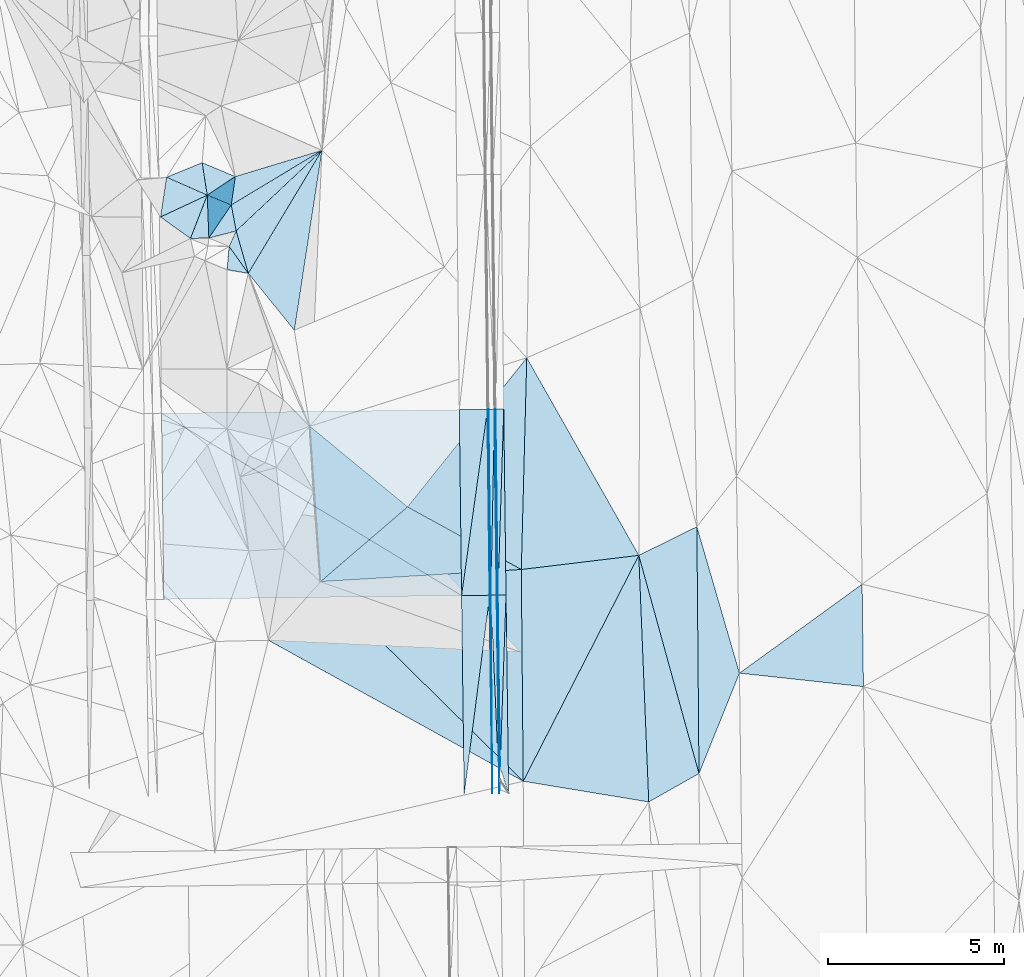
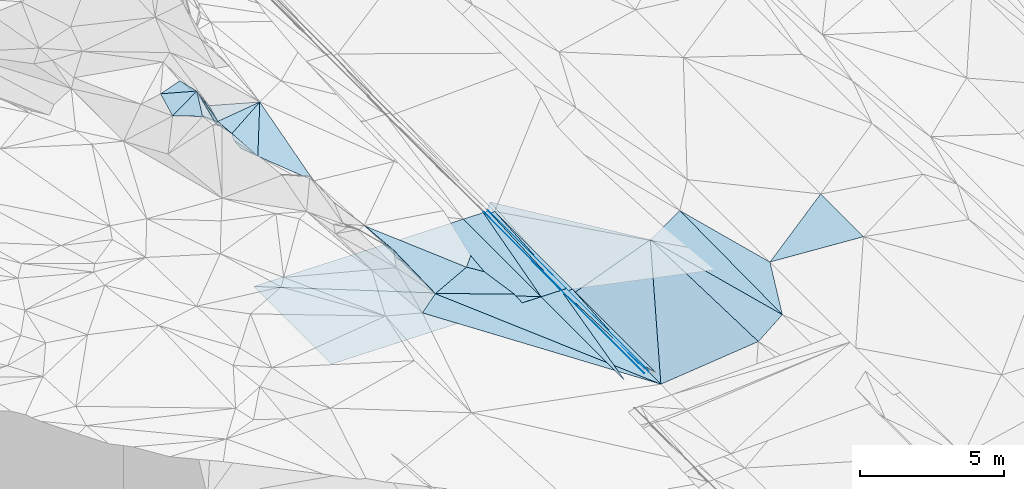
# One storey, part 15 of 275: 46 plates.
"""IFC2X3 building model written with IfcOpenShell, lengths in millimetres."""

from ifc_helpers import new_model, si_unit, frame, origin_with_axes, place, context, subcontext, project, spatial, polyline, outline, extrude, material, type_object, element, save


model = new_model("IFC2X3")

# Units and contexts
model_context = context("Model", 3, precision=1e-05, world=origin_with_axes())
body_context = subcontext(model_context, "Body", "Model", "MODEL_VIEW")
ifc_project = project(units=[si_unit("LENGTHUNIT", "METRE", prefix="MILLI"), si_unit("AREAUNIT", "SQUARE_METRE"), si_unit("VOLUMEUNIT", "CUBIC_METRE"), si_unit("MASSUNIT", "GRAM", prefix="KILO"), si_unit("TIMEUNIT", "SECOND"), si_unit("PLANEANGLEUNIT", "RADIAN"), si_unit("SOLIDANGLEUNIT", "STERADIAN"), si_unit("THERMODYNAMICTEMPERATUREUNIT", "DEGREE_CELSIUS"), si_unit("LUMINOUSINTENSITYUNIT", "LUMEN")], contexts=[model_context])

# Site, building, storey
site_placement = place(None, origin_with_axes())
site = spatial("IfcSite", under=ifc_project, at=site_placement, CompositionType="ELEMENT")
building_placement = place(site_placement, origin_with_axes())
building = spatial("IfcBuilding", under=site, at=building_placement, Name="Undefined", CompositionType="ELEMENT")
storey_placement = place(building_placement, origin_with_axes())
storey = spatial("IfcBuildingStorey", under=building, at=storey_placement, Name="Undefined", CompositionType="ELEMENT", Elevation=0.0)

# Plates
ifc_material = material()
plate_type_1 = type_object("IfcPlateType", PredefinedType="NOTDEFINED")
plate_1_placement = place(storey_placement, frame((-93645.5654127014, 6924.88176005127, 41050.6337426774), z_axis=(-0.970123201370092, -0.00671580462623567, -0.242519838635247), x_axis=(-0.242493457937885, -0.00450982198549851, 0.970142558783495)))
element("IfcPlate", 1, at=plate_1_placement, inside=storey, type_object=plate_type_1, material=ifc_material, Name="00_PR", context=body_context, shape_type="SweptSolid", body=[
    extrude(outline(polyline([(0.0, 0.0), (123.693176269531, -2.18278728425503e-11), (223.490829467773, 5268.44970703125), (0.0, 0.0)])), frame((-8.85201319254618e-08, 2.18876761149539e-07, -0.5000001331573), z_axis=(0.0, 0.0, 1.0), x_axis=(1.0, 0.0, 0.0)), (0.0, 0.0, 1.0), 1.0),
])
plate_2_placement = place(storey_placement, frame((-93582.0000382841, 2050.47414850637, 40946.8437420977), z_axis=(-0.970117044837282, -0.00748696234688832, -0.242521885014518), x_axis=(-0.0191726281131406, 0.998763884216836, 0.0458597199657052)))
element("IfcPlate", 2, at=plate_2_placement, inside=storey, type_object=plate_type_1, material=ifc_material, Name="00_PR", context=body_context, shape_type="SweptSolid", body=[
    extrude(outline(polyline([(0.0, 0.0), (4879.88134765625, -1.38970790430903e-09), (4874.3603515625, 123.569885253906), (0.0, 0.0)])), frame((-8.85201319254618e-08, 2.18876761149539e-07, -0.5000001331573), z_axis=(0.0, 0.0, 1.0), x_axis=(1.0, 0.0, 0.0)), (0.0, 0.0, 1.0), 1.0),
])
plate_3_placement = place(storey_placement, frame((-93601.8818309884, 1303.71746638813, 41050.9489987877), z_axis=(-0.97074095165136, -0.0076143507417692, -0.240008388290478), x_axis=(-0.0131045751041167, 0.999687507594542, 0.0212874909454562)))
element("IfcPlate", 3, at=plate_3_placement, inside=storey, type_object=plate_type_1, material=ifc_material, Name="00_PR", context=body_context, shape_type="SweptSolid", body=[
    extrude(outline(polyline([(0.0, 0.0), (5622.36279296875, -5.0931703299284e-11), (744.046630859375, 123.583992004395), (0.0, 0.0)])), frame((-8.85201319254618e-08, 2.18876761149539e-07, -0.5000001331573), z_axis=(0.0, 0.0, 1.0), x_axis=(1.0, 0.0, 0.0)), (0.0, 0.0, 1.0), 1.0),
])
plate_4_placement = place(storey_placement, frame((-93645.5654408981, 6924.88175349419, 41050.6338539226), z_axis=(-0.970178666674634, -0.00672655828869441, -0.2422975611578), x_axis=(-0.0178796491174188, 0.998877629724675, 0.0438611329431022)))
element("IfcPlate", 4, at=plate_4_placement, inside=storey, type_object=plate_type_1, material=ifc_material, Name="00_PR", context=body_context, shape_type="SweptSolid", body=[
    extrude(outline(polyline([(0.0, 0.0), (5273.18798828125, -2.29920260608196e-09), (5268.7587890625, 123.611724853516), (0.0, 0.0)])), frame((-8.85201319254618e-08, 2.18876761149539e-07, -0.5000001331573), z_axis=(0.0, 0.0, 1.0), x_axis=(1.0, 0.0, 0.0)), (0.0, 0.0, 1.0), 1.0),
])
plate_type_2 = type_object("IfcPlateType", PredefinedType="NOTDEFINED")
plate_5_placement = place(storey_placement, frame((-93939.3591804414, 12189.8120548934, 41282.1432122279), z_axis=(-0.0202381755240931, 0.0208694723215139, -0.999577351372308), x_axis=(0.999730993002575, 0.0117517851009575, -0.0199959290113252)))
element("IfcPlate", 5, at=plate_5_placement, inside=storey, type_object=plate_type_2, material=ifc_material, Name="00_PR", context=body_context, shape_type="SweptSolid", body=[
    extrude(outline(polyline([(0.0, 0.0), (30.0061073303223, -1.96450855582953e-10), (34.5950012207031, 5269.541015625), (0.0, 0.0)])), frame((-8.85201319254618e-08, 2.18876761149539e-07, -0.5000001331573), z_axis=(0.0, 0.0, 1.0), x_axis=(1.0, 0.0, 0.0)), (0.0, 0.0, 1.0), 1.0),
])
plate_6_placement = place(storey_placement, frame((-93845.0721593397, 6922.18920606923, 41170.2552141594), z_axis=(-0.0202593645784739, 0.0210187891176736, -0.999573793499461), x_axis=(0.00776926009786083, -0.999745493529568, -0.0211798669696531)))
element("IfcPlate", 6, at=plate_6_placement, inside=storey, type_object=plate_type_2, material=ifc_material, Name="00_PR", context=body_context, shape_type="SweptSolid", body=[
    extrude(outline(polyline([(0.0, 0.0), (5622.60400390625, 5.23868948221207e-10), (0.133674800395966, 30.0051765441895), (0.0, 0.0)])), frame((-8.85201319254618e-08, 2.18876761149539e-07, -0.5000001331573), z_axis=(0.0, 0.0, 1.0), x_axis=(1.0, 0.0, 0.0)), (0.0, 0.0, 1.0), 1.0),
])
plate_7_placement = place(storey_placement, frame((-93845.0721599937, 6922.18913180078, 41170.2552143476), z_axis=(-0.0202569271524092, 0.020869125753764, -0.999576978772828), x_axis=(-0.999720037211024, -0.0126488381103916, 0.0199963519984289)))
element("IfcPlate", 7, at=plate_7_placement, inside=storey, type_object=plate_type_2, material=ifc_material, Name="00_PR", context=body_context, shape_type="SweptSolid", body=[
    extrude(outline(polyline([(0.0, 0.0), (30.0054740905762, 1.32786226458848e-10), (29.8686790466309, 5269.56982421875), (0.0, 0.0)])), frame((-8.85201319254618e-08, 2.18876761149539e-07, -0.5000001331573), z_axis=(0.0, 0.0, 1.0), x_axis=(1.0, 0.0, 0.0)), (0.0, 0.0, 1.0), 1.0),
])
plate_type_3 = type_object("IfcPlateType", PredefinedType="NOTDEFINED")
plate_8_placement = place(storey_placement, frame((-93939.3591804414, 12189.8120548934, 41282.1432122279), z_axis=(-0.0202389360534142, 0.0208665514569433, -0.999577396952192), x_axis=(-0.138020329921821, -0.99026803217576, -0.0178777229819364)))
element("IfcPlate", 8, at=plate_8_placement, inside=storey, type_object=plate_type_3, material=ifc_material, Name="00_PR", context=body_context, shape_type="SweptSolid", body=[
    extrude(outline(polyline([(0.0, 0.0), (5329.9853515625, -2.91038304567337e-09), (119.44327545166, 791.195007324219), (0.0, 0.0)])), frame((-8.85201319254618e-08, 2.18876761149539e-07, -0.5000001331573), z_axis=(0.0, 0.0, 1.0), x_axis=(1.0, 0.0, 0.0)), (0.0, 0.0, 1.0), 1.0),
])
plate_9_placement = place(storey_placement, frame((-94675.0055140679, 6911.69801335539, 41186.8552116675), z_axis=(-0.0202569271524092, 0.020869125753764, -0.999576978772828), x_axis=(0.138020329921778, 0.990268032175784, 0.0178777229809464)))
element("IfcPlate", 9, at=plate_9_placement, inside=storey, type_object=plate_type_3, material=ifc_material, Name="00_PR", context=body_context, shape_type="SweptSolid", body=[
    extrude(outline(polyline([(0.0, 0.0), (5329.9853515625, -2.91038304567337e-09), (120.134590148926, 791.090393066406), (0.0, 0.0)])), frame((-8.85201319254618e-08, 2.18876761149539e-07, -0.5000001331573), z_axis=(0.0, 0.0, 1.0), x_axis=(1.0, 0.0, 0.0)), (0.0, 0.0, 1.0), 1.0),
])
plate_10_placement = place(storey_placement, frame((-93875.0692322722, 6921.80967036552, 41170.8552142515), z_axis=(-0.0202587211165812, 0.0210159665238338, -0.999573865889755), x_axis=(-0.127877384951844, -0.991621931419623, -0.0182570409840726)))
element("IfcPlate", 10, at=plate_10_placement, inside=storey, type_object=plate_type_3, material=ifc_material, Name="00_PR", context=body_context, shape_type="SweptSolid", body=[
    extrude(outline(polyline([(0.0, 0.0), (5679.2333984375, 5.54427970200777e-09), (112.028503417969, 792.278930664063), (0.0, 0.0)])), frame((-8.85201319254618e-08, 2.18876761149539e-07, -0.5000001331573), z_axis=(0.0, 0.0, 1.0), x_axis=(1.0, 0.0, 0.0)), (0.0, 0.0, 1.0), 1.0),
])
plate_type_4 = type_object("IfcPlateType", PredefinedType="NOTDEFINED")
plate_11_placement = place(storey_placement, frame((-101064.573224527, 17248.2101642047, 44049.5576733363), z_axis=(-0.448187377193277, 0.128640285215937, -0.884635377963245), x_axis=(0.703618186996102, 0.661171973151793, -0.260332611954175)))
element("IfcPlate", 11, at=plate_11_placement, inside=storey, type_object=plate_type_4, material=ifc_material, Name="00", context=body_context, shape_type="SweptSolid", body=[
    extrude(outline(polyline([(0.0, 0.0), (3457.11596679688, -1.42899807542562e-08), (-461.853179931641, 1210.40307617188), (0.0, 0.0)])), frame((-8.85201319254618e-08, 2.18876761149539e-07, -0.5000001331573), z_axis=(0.0, 0.0, 1.0), x_axis=(1.0, 0.0, 0.0)), (0.0, 0.0, 1.0), 1.0),
])
plate_type_5 = type_object("IfcPlateType", PredefinedType="NOTDEFINED")
plate_12_placement = place(storey_placement, frame((-93645.0641874655, 6924.89596715616, 41050.2553818344), z_axis=(0.0323286870442026, 0.0216982861628136, -0.999241732701149), x_axis=(0.999398415746245, 0.0118581941075014, 0.0325912539863774)))
element("IfcPlate", 12, at=plate_12_placement, inside=storey, type_object=plate_type_5, material=ifc_material, Name="00_PR", context=body_context, shape_type="SweptSolid", body=[
    extrude(outline(polyline([(0.0, 0.0), (230.123092651367, 8.1672624219209e-10), (2.34281849861145, 4875.92578125), (0.0, 0.0)])), frame((-8.85201319254618e-08, 2.18876761149539e-07, -0.5000001331573), z_axis=(0.0, 0.0, 1.0), x_axis=(1.0, 0.0, 0.0)), (0.0, 0.0, 1.0), 1.0),
])
plate_13_placement = place(storey_placement, frame((-93581.4988617455, 2050.48874275952, 40946.465380626), z_axis=(0.0322353035921878, 0.0217015404319437, -0.999244678917631), x_axis=(0.0340936249016322, 0.999158549318447, 0.0227995189625591)))
element("IfcPlate", 13, at=plate_13_placement, inside=storey, type_object=plate_type_5, material=ifc_material, Name="00_PR", context=body_context, shape_type="SweptSolid", body=[
    extrude(outline(polyline([(0.0, 0.0), (4881.2431640625, -7.56699591875076e-10), (-734.60791015625, 265.432464599609), (0.0, 0.0)])), frame((-8.85201319254618e-08, 2.18876761149539e-07, -0.5000001331573), z_axis=(0.0, 0.0, 1.0), x_axis=(1.0, 0.0, 0.0)), (0.0, 0.0, 1.0), 1.0),
])
plate_14_placement = place(storey_placement, frame((-93709.3869603134, 12193.536538526, 41161.543381076), z_axis=(0.0324231444584525, 0.0215025656848395, -0.999242903088331), x_axis=(0.999441979829045, 0.00733407710920215, 0.0325874250034465)))
element("IfcPlate", 14, at=plate_14_placement, inside=storey, type_object=plate_type_5, material=ifc_material, Name="00_PR", context=body_context, shape_type="SweptSolid", body=[
    extrude(outline(polyline([(0.0, 0.0), (230.150131225586, -1.19325704872608e-09), (22.019718170166, 5270.16259765625), (0.0, 0.0)])), frame((-8.85201319254618e-08, 2.18876761149539e-07, -0.5000001331573), z_axis=(0.0, 0.0, 1.0), x_axis=(1.0, 0.0, 0.0)), (0.0, 0.0, 1.0), 1.0),
])
plate_15_placement = place(storey_placement, frame((-93479.3653073142, 12195.2244773944, 41169.0433790673), z_axis=(0.0323311075206509, 0.0215055247423236, -0.999245821553458), x_axis=(0.0122003671086354, -0.999702491309144, -0.0211206039853343)))
element("IfcPlate", 15, at=plate_15_placement, inside=storey, type_object=plate_type_5, material=ifc_material, Name="00_PR", context=body_context, shape_type="SweptSolid", body=[
    extrude(outline(polyline([(0.0, 0.0), (5269.16748046875, -2.53203324973583e-09), (5269.248046875, 230.123077392578), (0.0, 0.0)])), frame((-8.85201319254618e-08, 2.18876761149539e-07, -0.5000001331573), z_axis=(0.0, 0.0, 1.0), x_axis=(1.0, 0.0, 0.0)), (0.0, 0.0, 1.0), 1.0),
])
plate_type_6 = type_object("IfcPlateType", PredefinedType="NOTDEFINED")
plate_16_placement = place(storey_placement, frame((-101264.525406492, 16809.9051070863, 44119.6058531871), z_axis=(-0.61529754767314, -0.00550289937896897, -0.788275742317271), x_axis=(0.52947580316291, -0.743715415912413, -0.408096500841673)))
element("IfcPlate", 16, at=plate_16_placement, inside=storey, type_object=plate_type_6, material=ifc_material, Name="00", context=body_context, shape_type="SweptSolid", body=[
    extrude(outline(polyline([(0.0, 0.0), (1024.267578125, -4.07453626394272e-09), (439.553131103516, 498.089385986328), (0.0, 0.0)])), frame((-8.85201319254618e-08, 2.18876761149539e-07, -0.5000001331573), z_axis=(0.0, 0.0, 1.0), x_axis=(1.0, 0.0, 0.0)), (0.0, 0.0, 1.0), 1.0),
])
plate_type_7 = type_object("IfcPlateType", PredefinedType="NOTDEFINED")
plate_17_placement = place(storey_placement, frame((-103181.213910905, 12081.0716305226, 41466.9972118872), z_axis=(-0.0202389360534142, 0.0208665514569433, -0.999577396952192), x_axis=(0.999730851009334, 0.0117629081130533, -0.0199964880135589)))
element("IfcPlate", 17, at=plate_17_placement, inside=storey, type_object=plate_type_7, material=ifc_material, Name="00_PR", context=body_context, shape_type="SweptSolid", body=[
    extrude(outline(polyline([(0.0, 0.0), (8444.1826171875, 4.79940354125574e-08), (8448.7138671875, 5270.26708984375), (0.0, 0.0)])), frame((-8.85201319254618e-08, 2.18876761149539e-07, -0.5000001331573), z_axis=(0.0, 0.0, 1.0), x_axis=(1.0, 0.0, 0.0)), (0.0, 0.0, 1.0), 1.0),
])
plate_type_8 = type_object("IfcPlateType", PredefinedType="NOTDEFINED")
plate_18_placement = place(storey_placement, frame((-94675.0055140679, 6911.69801335539, 41186.8552116675), z_axis=(-0.0202569030199797, 0.0208370011510417, -0.999577649441538), x_axis=(-0.999720171544753, -0.0126382401073049, 0.0199963370025367)))
element("IfcPlate", 18, at=plate_18_placement, inside=storey, type_object=plate_type_8, material=ifc_material, Name="00_PR", context=body_context, shape_type="SweptSolid", body=[
    extrude(outline(polyline([(0.0, 0.0), (8444.296875, -8.85665940586478e-09), (8444.0986328125, 5277.65966796875), (0.0, 0.0)])), frame((-8.85201319254618e-08, 2.18876761149539e-07, -0.5000001331573), z_axis=(0.0, 0.0, 1.0), x_axis=(1.0, 0.0, 0.0)), (0.0, 0.0, 1.0), 1.0),
])
plate_type_9 = type_object("IfcPlateType", PredefinedType="NOTDEFINED")
plate_19_placement = place(storey_placement, frame((-93739.3632348747, 12192.1651502543, 41281.5431138714), z_axis=(-0.000266925513515774, 0.0211180080918904, -0.999776954367824), x_axis=(0.0122002561209938, -0.999702511910539, -0.0211196929509057)))
element("IfcPlate", 19, at=plate_19_placement, inside=storey, type_object=plate_type_9, material=ifc_material, Name="00_PR", context=body_context, shape_type="SweptSolid", body=[
    extrude(outline(polyline([(0.0, 0.0), (5269.39501953125, 5.02041075378656e-09), (5269.46875, 170.000457763672), (0.0, 0.0)])), frame((-8.85201319254618e-08, 2.18876761149539e-07, -0.5000001331573), z_axis=(0.0, 0.0, 1.0), x_axis=(1.0, 0.0, 0.0)), (0.0, 0.0, 1.0), 1.0),
])
plate_20_placement = place(storey_placement, frame((-93601.3965926987, 1303.73191512591, 41050.5691161451), z_axis=(-0.000269046396220576, 0.0212857926622834, -0.999773395647621), x_axis=(-0.0433182301350207, 0.998834721274151, 0.0212774649608074)))
element("IfcPlate", 20, at=plate_20_placement, inside=storey, type_object=plate_type_9, material=ifc_material, Name="00_PR", context=body_context, shape_type="SweptSolid", body=[
    extrude(outline(polyline([(0.0, 0.0), (5625.01220703125, -1.35332811623812e-09), (5619.794921875, 169.920394897461), (0.0, 0.0)])), frame((-8.85201319254618e-08, 2.18876761149539e-07, -0.5000001331573), z_axis=(0.0, 0.0, 1.0), x_axis=(1.0, 0.0, 0.0)), (0.0, 0.0, 1.0), 1.0),
])
plate_21_placement = place(storey_placement, frame((-93845.0621548743, 6922.18925422905, 41170.2551136919), z_axis=(-0.000248503370106917, 0.0211176389078109, -0.999776966914639), x_axis=(-0.0122001081090381, 0.999702526264663, 0.0211190989906722)))
element("IfcPlate", 21, at=plate_21_placement, inside=storey, type_object=plate_type_9, material=ifc_material, Name="00_PR", context=body_context, shape_type="SweptSolid", body=[
    extrude(outline(polyline([(0.0, 0.0), (5269.54296875, -2.16823536902666e-09), (5269.46875, 169.99967956543), (0.0, 0.0)])), frame((-8.85201319254618e-08, 2.18876761149539e-07, -0.5000001331573), z_axis=(0.0, 0.0, 1.0), x_axis=(1.0, 0.0, 0.0)), (0.0, 0.0, 1.0), 1.0),
])
plate_type_10 = type_object("IfcPlateType", PredefinedType="NOTDEFINED")
plate_22_placement = place(storey_placement, frame((-98632.0619131774, 19533.9298409137, 43149.5441854395), z_axis=(-0.404735856799401, 0.0717772547405304, -0.911612259638256), x_axis=(-0.703618187001359, -0.661171973150323, 0.260332611943701)))
element("IfcPlate", 22, at=plate_22_placement, inside=storey, type_object=plate_type_10, material=ifc_material, Name="00", context=body_context, shape_type="SweptSolid", body=[
    extrude(outline(polyline([(0.0, 0.0), (3457.11596679688, -1.42899807542562e-08), (3099.75439453125, 669.696044921875), (0.0, 0.0)])), frame((-8.85201319254618e-08, 2.18876761149539e-07, -0.5000001331573), z_axis=(0.0, 0.0, 1.0), x_axis=(1.0, 0.0, 0.0)), (0.0, 0.0, 1.0), 1.0),
])
plate_type_11 = type_object("IfcPlateType", PredefinedType="NOTDEFINED")
plate_23_placement = place(storey_placement, frame((-101885.109645585, 18263.2431442404, 45519.6560911004), z_axis=(-0.642300626789221, 0.338203471940731, -0.687799619361199), x_axis=(0.0329851172156101, -0.884351557863485, -0.465654704847594)))
element("IfcPlate", 23, at=plate_23_placement, inside=storey, type_object=plate_type_11, material=ifc_material, Name="00", context=body_context, shape_type="SweptSolid", body=[
    extrude(outline(polyline([(0.0, 0.0), (1374.40893554688, -2.03726813197136e-09), (1143.61889648438, 668.981262207031), (0.0, 0.0)])), frame((-8.85201319254618e-08, 2.18876761149539e-07, -0.5000001331573), z_axis=(0.0, 0.0, 1.0), x_axis=(1.0, 0.0, 0.0)), (0.0, 0.0, 1.0), 1.0),
])
plate_type_12 = type_object("IfcPlateType", PredefinedType="NOTDEFINED")
plate_24_placement = place(storey_placement, frame((-102029.586247482, 19183.1785852913, 45449.7042533863), z_axis=(-0.788471929452885, -0.168727731845724, -0.591475247978343), x_axis=(0.614498423227815, -0.257568851976365, -0.74568758494567)))
element("IfcPlate", 24, at=plate_24_placement, inside=storey, type_object=plate_type_12, material=ifc_material, Name="00", context=body_context, shape_type="SweptSolid", body=[
    extrude(outline(polyline([(0.0, 0.0), (1528.79040527344, 7.76708475314081e-10), (273.549591064453, 893.124084472656), (0.0, 0.0)])), frame((-8.85201319254618e-08, 2.18876761149539e-07, -0.5000001331573), z_axis=(0.0, 0.0, 1.0), x_axis=(1.0, 0.0, 0.0)), (0.0, 0.0, 1.0), 1.0),
])
plate_type_13 = type_object("IfcPlateType", PredefinedType="NOTDEFINED")
plate_25_placement = place(storey_placement, frame((-100153.011487644, 5644.87280180324, 43192.5441032053), z_axis=(-0.409740088812783, -0.0284977083549322, -0.911757062072025), x_axis=(0.632670229604309, 0.711165901307489, -0.306547616839438)))
element("IfcPlate", 25, at=plate_25_placement, inside=storey, type_object=plate_type_13, material=ifc_material, Name="00", context=body_context, shape_type="SweptSolid", body=[
    extrude(outline(polyline([(0.0, 0.0), (2338.95141601563, -1.14523572847247e-08), (2685.6884765625, 8408.98046875), (0.0, 0.0)])), frame((-8.85201319254618e-08, 2.18876761149539e-07, -0.5000001331573), z_axis=(0.0, 0.0, 1.0), x_axis=(1.0, 0.0, 0.0)), (0.0, 0.0, 1.0), 1.0),
])
plate_type_14 = type_object("IfcPlateType", PredefinedType="NOTDEFINED")
plate_26_placement = place(storey_placement, frame((-98977.4007100656, 11710.2671167597, 42786.9616112853), z_axis=(-0.995040260432011, -0.0632667036507972, -0.076760695206329), x_axis=(0.0686978491437685, -0.995157032572144, -0.0703070838907781)))
element("IfcPlate", 26, at=plate_26_placement, inside=storey, type_object=plate_type_14, material=ifc_material, Name="00", context=body_context, shape_type="SweptSolid", body=[
    extrude(outline(polyline([(0.0, 0.0), (4423.45166015625, -2.23371898755431e-09), (1838.59497070313, 163.152557373047), (0.0, 0.0)])), frame((-8.85201319254618e-08, 2.18876761149539e-07, -0.5000001331573), z_axis=(0.0, 0.0, 1.0), x_axis=(1.0, 0.0, 0.0)), (0.0, 0.0, 1.0), 1.0),
])
plate_type_15 = type_object("IfcPlateType", PredefinedType="NOTDEFINED")
plate_27_placement = place(storey_placement, frame((-88004.9118452655, 8863.6660507319, 41312.5019723424), z_axis=(0.0850146214673599, 0.0263565491911969, -0.996031046931517), x_axis=(0.00862656053928688, -0.999632079249978, -0.0257155320307991)))
element("IfcPlate", 27, at=plate_27_placement, inside=storey, type_object=plate_type_15, material=ifc_material, Name="00", context=body_context, shape_type="SweptSolid", body=[
    extrude(outline(polyline([(0.0, 0.0), (6999.66064453125, 6.69388100504875e-10), (801.656555175781, 1659.23950195313), (0.0, 0.0)])), frame((-8.85201319254618e-08, 2.18876761149539e-07, -0.5000001331573), z_axis=(0.0, 0.0, 1.0), x_axis=(1.0, 0.0, 0.0)), (0.0, 0.0, 1.0), 1.0),
])
plate_type_16 = type_object("IfcPlateType", PredefinedType="NOTDEFINED")
plate_28_placement = place(storey_placement, frame((-100722.150896981, 16048.1940245985, 43701.5746054098), z_axis=(-0.516037912987176, 0.0994567816457765, -0.850772132209621), x_axis=(-0.529475803163294, 0.743715415912012, 0.408096500841906)))
element("IfcPlate", 28, at=plate_28_placement, inside=storey, type_object=plate_type_16, material=ifc_material, Name="00", context=body_context, shape_type="SweptSolid", body=[
    extrude(outline(polyline([(0.0, 0.0), (1024.267578125, -4.07453626394272e-09), (1215.79956054688, 447.454467773438), (0.0, 0.0)])), frame((-8.85201319254618e-08, 2.18876761149539e-07, -0.5000001331573), z_axis=(0.0, 0.0, 1.0), x_axis=(1.0, 0.0, 0.0)), (0.0, 0.0, 1.0), 1.0),
])
plate_type_17 = type_object("IfcPlateType", PredefinedType="NOTDEFINED")
plate_29_placement = place(storey_placement, frame((-92981.7057955167, 7650.82639592646, 40267.5337525457), z_axis=(-0.359780730989057, -0.032669508858295, -0.932464760084765), x_axis=(-0.9308364911966, -0.0560273786412613, 0.361115437913406)))
element("IfcPlate", 29, at=plate_29_placement, inside=storey, type_object=plate_type_17, material=ifc_material, Name="00", context=body_context, shape_type="SweptSolid", body=[
    extrude(outline(polyline([(0.0, 0.0), (6114.38818359375, -1.47265382111073e-08), (3328.95971679688, 1964.29418945313), (0.0, 0.0)])), frame((-8.85201319254618e-08, 2.18876761149539e-07, -0.5000001331573), z_axis=(0.0, 0.0, 1.0), x_axis=(1.0, 0.0, 0.0)), (0.0, 0.0, 1.0), 1.0),
])
plate_type_18 = type_object("IfcPlateType", PredefinedType="NOTDEFINED")
plate_30_placement = place(storey_placement, frame((-99416.0329505814, 14434.4478682212, 43179.5273468296), z_axis=(-0.323274460149926, 0.0441404265525661, -0.945275222439757), x_axis=(-0.610113060475671, 0.753854843503015, 0.243854317911441)))
element("IfcPlate", 30, at=plate_30_placement, inside=storey, type_object=plate_type_18, material=ifc_material, Name="00", context=body_context, shape_type="SweptSolid", body=[
    extrude(outline(polyline([(0.0, 0.0), (2140.62231445313, 7.33416527509689e-09), (3358.607421875, 3916.619140625), (0.0, 0.0)])), frame((-8.85201319254618e-08, 2.18876761149539e-07, -0.5000001331573), z_axis=(0.0, 0.0, 1.0), x_axis=(1.0, 0.0, 0.0)), (0.0, 0.0, 1.0), 1.0),
])
plate_type_19 = type_object("IfcPlateType", PredefinedType="NOTDEFINED")
plate_31_placement = place(storey_placement, frame((-101839.879715682, 17047.7224713185, 44879.7625268961), z_axis=(-0.852525037747415, 0.218275198474921, -0.474928413284046), x_axis=(-0.0329851172154088, 0.884351557861787, 0.465654704850832)))
element("IfcPlate", 31, at=plate_31_placement, inside=storey, type_object=plate_type_19, material=ifc_material, Name="00", context=body_context, shape_type="SweptSolid", body=[
    extrude(outline(polyline([(0.0, 0.0), (1374.40893554688, -2.03726813197136e-09), (477.005035400391, 1248.26525878906), (0.0, 0.0)])), frame((-8.85201319254618e-08, 2.18876761149539e-07, -0.5000001331573), z_axis=(0.0, 0.0, 1.0), x_axis=(1.0, 0.0, 0.0)), (0.0, 0.0, 1.0), 1.0),
])
plate_type_20 = type_object("IfcPlateType", PredefinedType="NOTDEFINED")
plate_32_placement = place(storey_placement, frame((-101884.797107253, 18263.0347780593, 45519.501609652), z_axis=(-0.017226695601544, -0.0785284482506202, -0.996763022876552), x_axis=(-0.915383319328059, 0.402270378971654, -0.0158720161903486)))
element("IfcPlate", 32, at=plate_32_placement, inside=storey, type_object=plate_type_20, material=ifc_material, Name="00", context=body_context, shape_type="SweptSolid", body=[
    extrude(outline(polyline([(0.0, 0.0), (1260.07934570313, -2.60115484707057e-09), (503.460357666016, 786.783142089844), (0.0, 0.0)])), frame((-8.85201319254618e-08, 2.18876761149539e-07, -0.5000001331573), z_axis=(0.0, 0.0, 1.0), x_axis=(1.0, 0.0, 0.0)), (0.0, 0.0, 1.0), 1.0),
])
plate_type_21 = type_object("IfcPlateType", PredefinedType="NOTDEFINED")
plate_33_placement = place(storey_placement, frame((-101089.987440241, 18789.6019526316, 44309.5718581889), z_axis=(-0.469401596565141, 0.215569993689732, -0.856266149606947), x_axis=(0.872220379182934, 0.264161463156277, -0.411643451935184)))
element("IfcPlate", 33, at=plate_33_placement, inside=storey, type_object=plate_type_21, material=ifc_material, Name="00", context=body_context, shape_type="SweptSolid", body=[
    extrude(outline(polyline([(0.0, 0.0), (2817.97265625, 1.53740984387696e-08), (-254.686645507813, 784.687683105469), (0.0, 0.0)])), frame((-8.85201319254618e-08, 2.18876761149539e-07, -0.5000001331573), z_axis=(0.0, 0.0, 1.0), x_axis=(1.0, 0.0, 0.0)), (0.0, 0.0, 1.0), 1.0),
])
plate_type_22 = type_object("IfcPlateType", PredefinedType="NOTDEFINED")
plate_34_placement = place(storey_placement, frame((-101204.465008951, 17984.6495080802, 44169.7629809299), z_axis=(-0.856543474478056, 0.204053378864002, -0.474020563797863), x_axis=(-0.442803421195856, 0.181171054993948, 0.878124238937535)))
element("IfcPlate", 34, at=plate_34_placement, inside=storey, type_object=plate_type_22, material=ifc_material, Name="00", context=body_context, shape_type="SweptSolid", body=[
    extrude(outline(polyline([(0.0, 0.0), (1537.36791992188, -6.31189323030412e-09), (218.165084838867, 795.615478515625), (0.0, 0.0)])), frame((-8.85201319254618e-08, 2.18876761149539e-07, -0.5000001331573), z_axis=(0.0, 0.0, 1.0), x_axis=(1.0, 0.0, 0.0)), (0.0, 0.0, 1.0), 1.0),
])
plate_type_23 = type_object("IfcPlateType", PredefinedType="NOTDEFINED")
plate_35_placement = place(storey_placement, frame((-101204.40045657, 17984.5343540533, 44169.6571561846), z_axis=(-0.727439015285672, -0.0262544640365574, -0.685669878409695), x_axis=(0.184022638265779, -0.970125943422213, -0.158086439977829)))
element("IfcPlate", 35, at=plate_35_placement, inside=storey, type_object=plate_type_23, material=ifc_material, Name="00", context=body_context, shape_type="SweptSolid", body=[
    extrude(outline(polyline([(0.0, 0.0), (759.078369140625, -7.27595761418343e-11), (679.771667480469, 1150.48266601563), (0.0, 0.0)])), frame((-8.85201319254618e-08, 2.18876761149539e-07, -0.5000001331573), z_axis=(0.0, 0.0, 1.0), x_axis=(1.0, 0.0, 0.0)), (0.0, 0.0, 1.0), 1.0),
])
plate_type_24 = type_object("IfcPlateType", PredefinedType="NOTDEFINED")
plate_36_placement = place(storey_placement, frame((-101884.729440345, 18263.1157297001, 45519.5052440118), z_axis=(0.118113007133873, 0.0833744038205085, -0.989493823292176), x_axis=(-0.358170208718382, -0.925813442771942, -0.120762455959601)))
element("IfcPlate", 36, at=plate_36_placement, inside=storey, type_object=plate_type_24, material=ifc_material, Name="00", context=body_context, shape_type="SweptSolid", body=[
    extrude(outline(polyline([(0.0, 0.0), (1324.9150390625, 2.60479282587767e-09), (1071.23840332031, 1014.42010498047), (0.0, 0.0)])), frame((-8.85201319254618e-08, 2.18876761149539e-07, -0.5000001331573), z_axis=(0.0, 0.0, 1.0), x_axis=(1.0, 0.0, 0.0)), (0.0, 0.0, 1.0), 1.0),
])
plate_type_25 = type_object("IfcPlateType", PredefinedType="NOTDEFINED")
plate_37_placement = place(storey_placement, frame((-103207.942364263, 17645.370958927, 45309.5077334371), z_axis=(0.0845538750603789, 0.153560819057266, -0.98451496538282), x_axis=(0.147194760816431, 0.975288041031285, 0.164763282953307)))
element("IfcPlate", 37, at=plate_37_placement, inside=storey, type_object=plate_type_25, material=ifc_material, Name="00", context=body_context, shape_type="SweptSolid", body=[
    extrude(outline(polyline([(0.0, 0.0), (1153.16955566406, -1.01863406598568e-10), (831.881164550781, 1218.43090820313), (0.0, 0.0)])), frame((-8.85201319254618e-08, 2.18876761149539e-07, -0.5000001331573), z_axis=(0.0, 0.0, 1.0), x_axis=(1.0, 0.0, 0.0)), (0.0, 0.0, 1.0), 1.0),
])
plate_type_26 = type_object("IfcPlateType", PredefinedType="NOTDEFINED")
plate_38_placement = place(storey_placement, frame((-89651.0827223776, 8051.67433772882, 41150.5164647007), z_axis=(0.253424630268021, 0.0247274805160375, -0.967039041859658), x_axis=(-0.960126094927729, -0.115555687532935, -0.254567800237225)))
element("IfcPlate", 38, at=plate_38_placement, inside=storey, type_object=plate_type_26, material=ifc_material, Name="00", context=body_context, shape_type="SweptSolid", body=[
    extrude(outline(polyline([(0.0, 0.0), (3468.6240234375, 1.15396687760949e-08), (2577.21411132813, 5939.623046875), (0.0, 0.0)])), frame((-8.85201319254618e-08, 2.18876761149539e-07, -0.5000001331573), z_axis=(0.0, 0.0, 1.0), x_axis=(1.0, 0.0, 0.0)), (0.0, 0.0, 1.0), 1.0),
])
plate_type_27 = type_object("IfcPlateType", PredefinedType="NOTDEFINED")
plate_39_placement = place(storey_placement, frame((-98673.2266295279, 7308.28762864796, 42475.5442957699), z_axis=(-0.409989387379493, 0.0360855733181295, -0.911376175700512), x_axis=(-0.0686978496387501, 0.995157032529676, 0.0703070840082368)))
element("IfcPlate", 39, at=plate_39_placement, inside=storey, type_object=plate_type_27, material=ifc_material, Name="00", context=body_context, shape_type="SweptSolid", body=[
    extrude(outline(polyline([(0.0, 0.0), (4423.45166015625, -2.23371898755431e-09), (1864.35852050781, 2853.28442382813), (0.0, 0.0)])), frame((-8.85201319254618e-08, 2.18876761149539e-07, -0.5000001331573), z_axis=(0.0, 0.0, 1.0), x_axis=(1.0, 0.0, 0.0)), (0.0, 0.0, 1.0), 1.0),
])
plate_type_28 = type_object("IfcPlateType", PredefinedType="NOTDEFINED")
plate_40_placement = place(storey_placement, frame((-89651.1650770745, 8051.67565218755, 41150.5021462286), z_axis=(0.0886990577314641, 0.0273721718438745, -0.995682299413874), x_axis=(0.265986619466737, -0.963972638686349, -0.00280537497220057)))
element("IfcPlate", 40, at=plate_40_placement, inside=storey, type_object=plate_type_28, material=ifc_material, Name="00", context=body_context, shape_type="SweptSolid", body=[
    extrude(outline(polyline([(0.0, 0.0), (6416.25537109375, -9.00763552635908e-09), (6813.453125, 1593.869140625), (0.0, 0.0)])), frame((-8.85201319254618e-08, 2.18876761149539e-07, -0.5000001331573), z_axis=(0.0, 0.0, 1.0), x_axis=(1.0, 0.0, 0.0)), (0.0, 0.0, 1.0), 1.0),
])
plate_type_29 = type_object("IfcPlateType", PredefinedType="NOTDEFINED")
plate_41_placement = place(storey_placement, frame((-92826.9455707076, 13651.8749963677, 40461.5275223975), z_axis=(-0.324966211276148, 0.0389270085001602, -0.944924150150717), x_axis=(-0.0257641004078798, -0.99914608722791, -0.0323002710101837)))
element("IfcPlate", 41, at=plate_41_placement, inside=storey, type_object=plate_type_29, material=ifc_material, Name="00", context=body_context, shape_type="SweptSolid", body=[
    extrude(outline(polyline([(0.0, 0.0), (6006.1416015625, -2.895831130445e-09), (4278.908203125, 3457.90234375), (0.0, 0.0)])), frame((-8.85201319254618e-08, 2.18876761149539e-07, -0.5000001331573), z_axis=(0.0, 0.0, 1.0), x_axis=(1.0, 0.0, 0.0)), (0.0, 0.0, 1.0), 1.0),
])
plate_type_30 = type_object("IfcPlateType", PredefinedType="NOTDEFINED")
plate_42_placement = place(storey_placement, frame((-92927.5936862551, 1648.01599052798, 40070.5164623144), z_axis=(0.25231142957566, 0.0339979651410422, -0.967048644521957), x_axis=(-0.00895824853764322, 0.999421826944087, 0.032798805022155)))
element("IfcPlate", 42, at=plate_42_placement, inside=storey, type_object=plate_type_30, material=ifc_material, Name="00", context=body_context, shape_type="SweptSolid", body=[
    extrude(outline(polyline([(0.0, 0.0), (6006.31640625, -5.96628524363041e-10), (6406.03125, 3445.51611328125), (0.0, 0.0)])), frame((-8.85201319254618e-08, 2.18876761149539e-07, -0.5000001331573), z_axis=(0.0, 0.0, 1.0), x_axis=(1.0, 0.0, 0.0)), (0.0, 0.0, 1.0), 1.0),
])
plate_type_31 = type_object("IfcPlateType", PredefinedType="NOTDEFINED")
plate_43_placement = place(storey_placement, frame((-87944.5612078756, 1866.58029034567, 41132.5002510357), z_axis=(0.0202903747739092, 0.0258861790502666, -0.99945895684901), x_axis=(-0.00862656066003115, 0.999632079248404, 0.0257155320515031)))
element("IfcPlate", 43, at=plate_43_placement, inside=storey, type_object=plate_type_31, material=ifc_material, Name="00", context=body_context, shape_type="SweptSolid", body=[
    extrude(outline(polyline([(0.0, 0.0), (6999.66064453125, 6.69388100504875e-10), (2837.451171875, 1172.00720214844), (0.0, 0.0)])), frame((-8.85201319254618e-08, 2.18876761149539e-07, -0.5000001331573), z_axis=(0.0, 0.0, 1.0), x_axis=(1.0, 0.0, 0.0)), (0.0, 0.0, 1.0), 1.0),
])
plate_type_32 = type_object("IfcPlateType", PredefinedType="NOTDEFINED")
plate_44_placement = place(storey_placement, frame((-89651.0826780497, 8051.67864082811, 41150.5166058233), z_axis=(0.253504869712489, 0.0333385520708349, -0.96675944369728), x_axis=(0.0403510905547479, -0.998900496884625, -0.0238660179898459)))
element("IfcPlate", 44, at=plate_44_placement, inside=storey, type_object=plate_type_32, material=ifc_material, Name="00", context=body_context, shape_type="SweptSolid", body=[
    extrude(outline(polyline([(0.0, 0.0), (6997.39697265625, 7.71251507103443e-10), (6290.1865234375, 3652.72119140625), (0.0, 0.0)])), frame((-8.85201319254618e-08, 2.18876761149539e-07, -0.5000001331573), z_axis=(0.0, 0.0, 1.0), x_axis=(1.0, 0.0, 0.0)), (0.0, 0.0, 1.0), 1.0),
])
plate_type_33 = type_object("IfcPlateType", PredefinedType="NOTDEFINED")
plate_45_placement = place(storey_placement, frame((-83319.8746322754, 7233.86799871522, 41359.5002192266), z_axis=(0.0221824960167073, 0.0209413022382429, -0.999534591062778), x_axis=(0.0127230315115963, -0.999705548935313, -0.0206625239770009)))
element("IfcPlate", 45, at=plate_45_placement, inside=storey, type_object=plate_type_33, material=ifc_material, Name="00", context=body_context, shape_type="SweptSolid", body=[
    extrude(outline(polyline([(0.0, 0.0), (2903.80786132813, 6.11180439591408e-10), (2479.08959960938, 3510.13037109375), (0.0, 0.0)])), frame((-8.85201319254618e-08, 2.18876761149539e-07, -0.5000001331573), z_axis=(0.0, 0.0, 1.0), x_axis=(1.0, 0.0, 0.0)), (0.0, 0.0, 1.0), 1.0),
])
plate_type_34 = type_object("IfcPlateType", PredefinedType="NOTDEFINED")
plate_46_placement = place(storey_placement, frame((-98673.203140601, 7308.28324226639, 42475.5342842881), z_axis=(-0.36297711748336, 0.0273128826661235, -0.93139766943231), x_axis=(0.930836491223247, 0.05602737856429, -0.361115437856661)))
element("IfcPlate", 46, at=plate_46_placement, inside=storey, type_object=plate_type_34, material=ifc_material, Name="00", context=body_context, shape_type="SweptSolid", body=[
    extrude(outline(polyline([(0.0, 0.0), (6114.38818359375, -1.47265382111073e-08), (5899.2890625, 6002.46337890625), (0.0, 0.0)])), frame((-8.85201319254618e-08, 2.18876761149539e-07, -0.5000001331573), z_axis=(0.0, 0.0, 1.0), x_axis=(1.0, 0.0, 0.0)), (0.0, 0.0, 1.0), 1.0),
])

save(model, "model.ifc")
